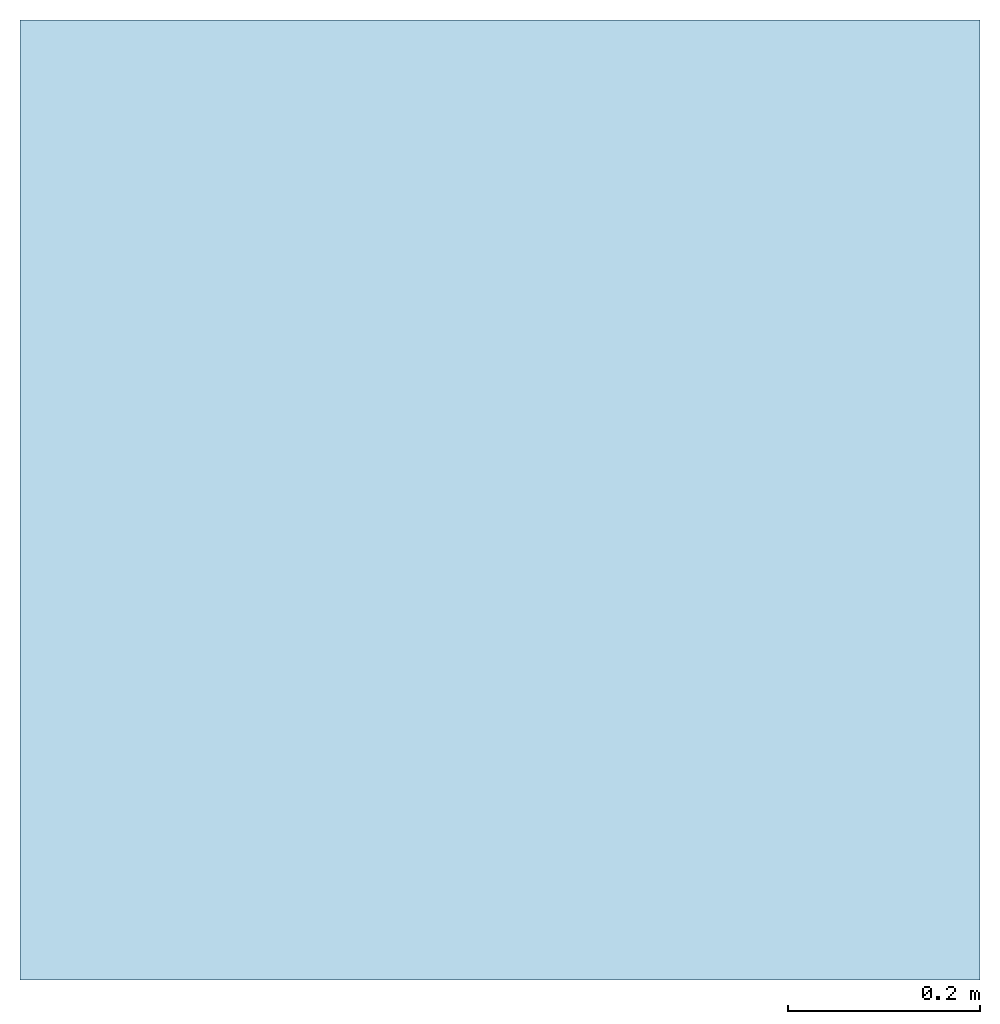
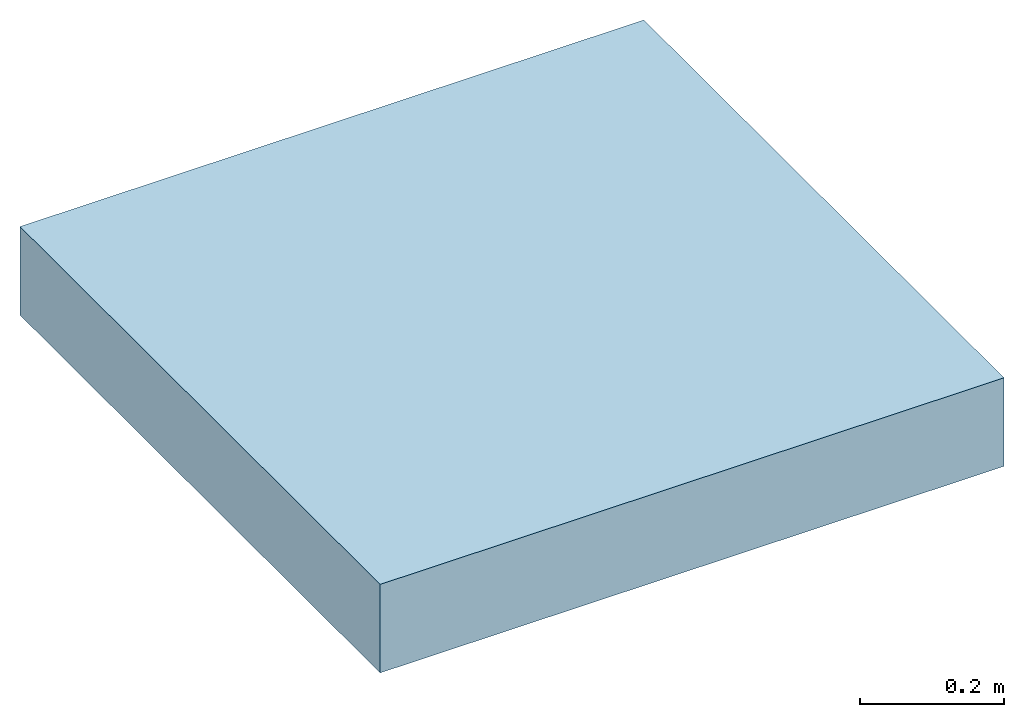
# Not in any storey: 1 footing, 1 slab.
"""IFC4 model written with IfcOpenShell, lengths in millimetres."""

from ifc_helpers import new_model, entity, si_unit, converted_unit, frame, origin_with_axes, origin_2d_with_axis, place, context, subcontext, project, indexed_curve, outline, extrude, material, layer, layer_set, layer_usage, type_object, element, save


model = new_model("IFC4")

# Units and contexts
model_context = context("Model", 3, precision=1e-05, world=origin_with_axes())
plan_context = context("Plan", 2, precision=1e-05, world=origin_2d_with_axis())
body_context = subcontext(model_context, "Body", "Model", "MODEL_VIEW")
ifc_project = project(units=[si_unit("AREAUNIT", "SQUARE_METRE"), si_unit("VOLUMEUNIT", "CUBIC_METRE"), si_unit("LENGTHUNIT", "METRE", prefix="MILLI"), converted_unit("PLANEANGLEUNIT", "degree", entity("IfcReal", 0.0174532925199433), si_unit("PLANEANGLEUNIT", "RADIAN"), dimensions=[0, 0, 0, 0, 0, 0, 0])], contexts=[model_context, plan_context])

# Footing
footing_placement = place(None, frame((-960.05642414093, 615.545749664307, -899.999976158142), z_axis=(0.0, 0.0, 1.0), x_axis=(1.0, 0.0, 0.0)))
element("IfcFooting", 1, at=footing_placement, Name="FTG450x150", context=body_context, shape_type="SweptSolid", body=[
    extrude(outline(indexed_curve([(0.0, 0.0), (1000.0, 0.0), (1000.0, 1000.0), (0.0, 1000.0), (0.0, 0.0)])), None, (0.0, 0.0, 1.0), 150.0),
])

# Slab
ifc_material = material(Name="Mass Concrete", Category="Concrete")
ifc_layer = layer(ifc_material, 150.0, Name="Foundation Footing Layer", Category="Substrate", Priority=1)
ifc_layer_set = layer_set([ifc_layer])
ifc_layer_usage = layer_usage(ifc_layer_set, "AXIS3", "POSITIVE", 0.0)
slab_type = type_object("IfcSlabType", Name="FLR150", PredefinedType="NOTDEFINED", material=ifc_layer_set)
slab_placement = place(None, frame((-960.05642414093, 615.545749664307, -899.999976158142), z_axis=(0.0, 0.0, 1.0), x_axis=(1.0, 0.0, 0.0)))
element("IfcSlab", 2, at=slab_placement, type_object=slab_type, material=ifc_layer_usage, Name="FLR150", context=body_context, shape_type="SweptSolid", body=[
    extrude(outline(indexed_curve([(0.0, 0.0), (1000.0, 0.0), (1000.0, 1000.0), (0.0, 1000.0), (0.0, 0.0)])), None, (0.0, 0.0, 1.0), 150.0),
])

save(model, "model.ifc")
